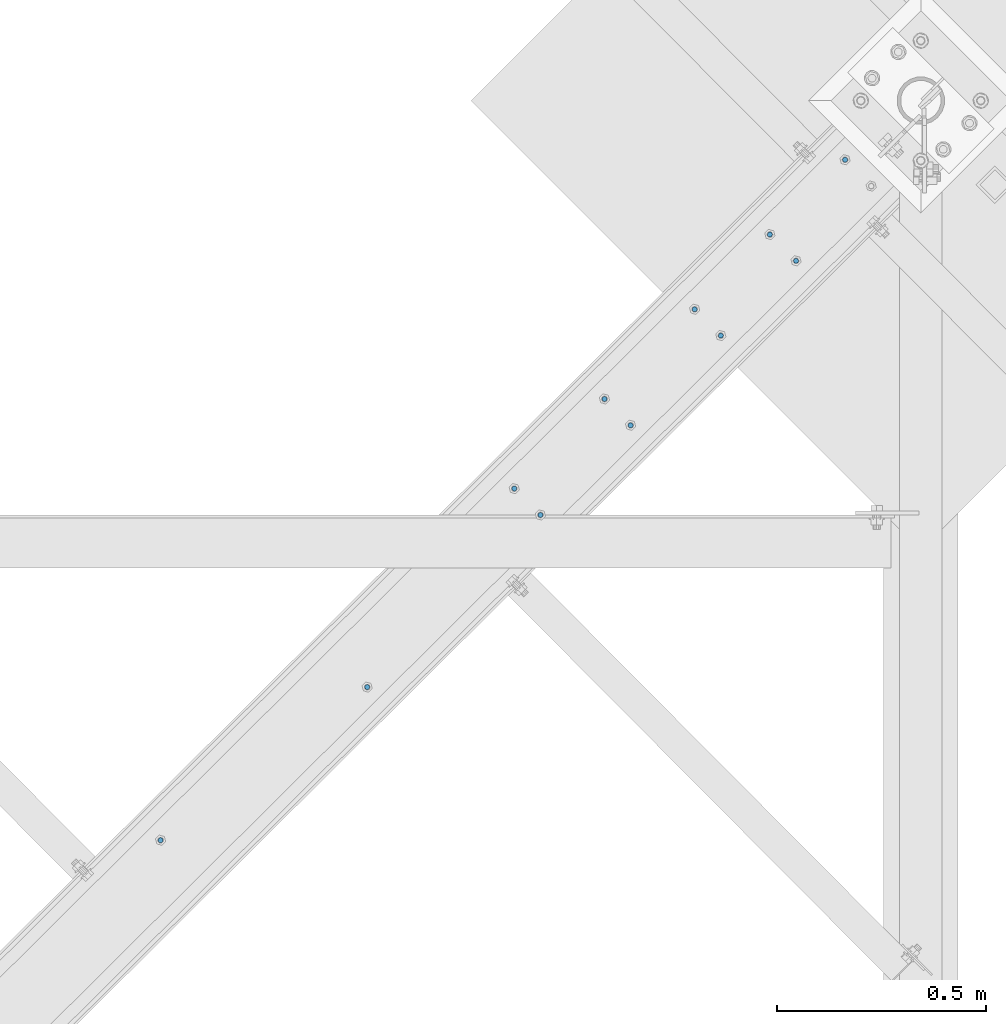
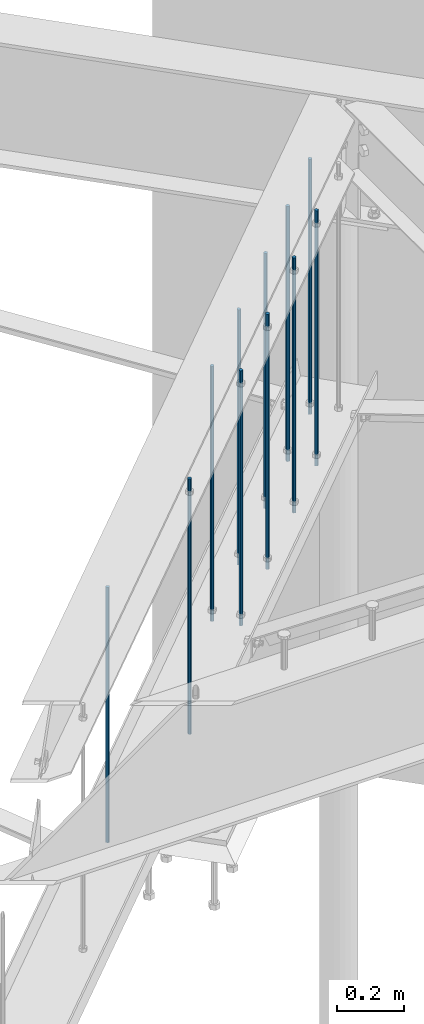
# One storey, part 278 of 975: 11 columns.
"""IFC2X3 building model written with IfcOpenShell, lengths in millimetres."""

from ifc_helpers import new_model, si_unit, frame, origin_with_axes, place, context, subcontext, project, spatial, faceted_brep, material, type_object, element, save


model = new_model("IFC2X3")

# Units and contexts
model_context = context("Model", 3, precision=1e-05, world=origin_with_axes())
body_context = subcontext(model_context, "Body", "Model", "MODEL_VIEW")
ifc_project = project(units=[si_unit("LENGTHUNIT", "METRE", prefix="MILLI"), si_unit("AREAUNIT", "SQUARE_METRE"), si_unit("VOLUMEUNIT", "CUBIC_METRE"), si_unit("MASSUNIT", "GRAM", prefix="KILO"), si_unit("TIMEUNIT", "SECOND"), si_unit("PLANEANGLEUNIT", "RADIAN"), si_unit("SOLIDANGLEUNIT", "STERADIAN"), si_unit("THERMODYNAMICTEMPERATUREUNIT", "DEGREE_CELSIUS"), si_unit("LUMINOUSINTENSITYUNIT", "LUMEN")], contexts=[model_context])

# Site, building, storey
site_placement = place(None, origin_with_axes())
site = spatial("IfcSite", under=ifc_project, at=site_placement, CompositionType="ELEMENT")
building_placement = place(site_placement, origin_with_axes())
building = spatial("IfcBuilding", under=site, at=building_placement, Name="Undefined", CompositionType="ELEMENT")
storey_placement = place(building_placement, origin_with_axes())
storey = spatial("IfcBuildingStorey", under=building, at=storey_placement, Name="Undefined", CompositionType="ELEMENT", Elevation=0.0)

# Columns
ifc_material = material(Name="STEEL/A36")
column_type = type_object("IfcColumnType", PredefinedType="NOTDEFINED")
for number, where, z_axis, x_axis, name in (
    (1, (29533.3491607856, 15580.1320269551, 2870.2), (-0.705007718837806, 0.709199630836842, 0.0), (0.0, 0.0, 1.0), "ALL-THREAD ROD"),
    (2, (29470.6739694094, 15643.1798689956, 2870.2), (-0.705007718837806, 0.709199630836842, 0.0), (0.0, 0.0, 1.0), "ALL-THREAD ROD"),
    (3, (29290.5372778651, 15464.1078936353, 2870.2), (-0.705007718837806, 0.709199630836842, 0.0), (0.0, 0.0, 1.0), "ALL-THREAD ROD"),
    (4, (29074.3732480118, 15249.221523203, 2870.2), (-0.705007718837806, 0.709199630836842, 0.0), (0.0, 0.0, 1.0), "ALL-THREAD ROD"),
    (5, (28920.8844095347, 14971.2873107301, 2870.2), (-0.705007718837806, 0.709199630836842, 0.0), (0.0, 0.0, 1.0), "ALL-THREAD ROD"),
    (6, (29137.048439388, 15186.1736811624, 2870.2), (-0.705007718837806, 0.709199630836842, 0.0), (0.0, 0.0, 1.0), "ALL-THREAD ROD"),
    (7, (29650.8106609538, 15822.251844356, 2870.2), (-0.705007718837806, 0.709199630836842, 0.0), (0.0, 0.0, 1.0), "ALL-THREAD ROD"),
    (8, (29353.2124692412, 15401.0600515948, 2870.2), (-0.705007718837806, 0.709199630836842, 0.0), (0.0, 0.0, 1.0), "ALL-THREAD ROD"),
    (9, (28505.8688346159, 14558.7247274552, 2870.2), (-0.705007718837806, 0.709199630836842, 0.0), (0.0, 0.0, 1.0), "ALL-THREAD ROD"),
    (10, (28858.2092181586, 15034.3351527706, 2870.2), (-0.705007718837806, 0.709199630836842, 0.0), (0.0, 0.0, 1.0), "ALL-THREAD ROD"),
    (11, (28010.8662945591, 14192.0002304974, 2870.2), (-0.705007718837806, 0.709199630836842, 0.0), (0.0, 0.0, 1.0), "ALL-THREAD ROD"),
):
    element("IfcColumn", number, at=place(storey_placement, frame(where, z_axis=z_axis, x_axis=x_axis)), inside=storey, type_object=column_type, material=ifc_material, Name=name, context=body_context, shape_type="Brep", body=[
        faceted_brep([(0.0, -6.34999999998763, -3.63797880709171e-12), (0.0, -4.49012806052269, -4.49012806054634), (931.8625, -4.49012806052269, -4.49012806054634), (931.8625, -6.34999999998763, -3.63797880709171e-12), (0.0, 7.27595761418343e-12, -6.35000000000764), (931.8625, 7.27595761418343e-12, -6.35000000000764), (0.0, 4.49012806053724, -4.49012806053906), (931.8625, 4.49012806053724, -4.49012806053906), (0.0, 6.34999999999491, 5.45696821063757e-12), (931.8625, 6.34999999999491, 5.45696821063757e-12), (0.0, 4.49012806052633, 4.49012806054634), (931.8625, 4.49012806052633, 4.49012806054634), (0.0, 0.0, 6.35000000000764), (931.8625, 0.0, 6.35000000000764), (0.0, -4.49012806053361, 4.49012806053543), (931.8625, -4.49012806053361, 4.49012806053543)], [[[0, 1, 2, 3]], [[1, 4, 5, 2]], [[4, 6, 7, 5]], [[6, 8, 9, 7]], [[8, 10, 11, 9]], [[10, 12, 13, 11]], [[12, 14, 15, 13]], [[14, 0, 3, 15]], [[5, 7, 9, 11, 13, 15, 3, 2]], [[14, 12, 10, 8, 6, 4, 1, 0]]]),
    ])

save(model, "model.ifc")
